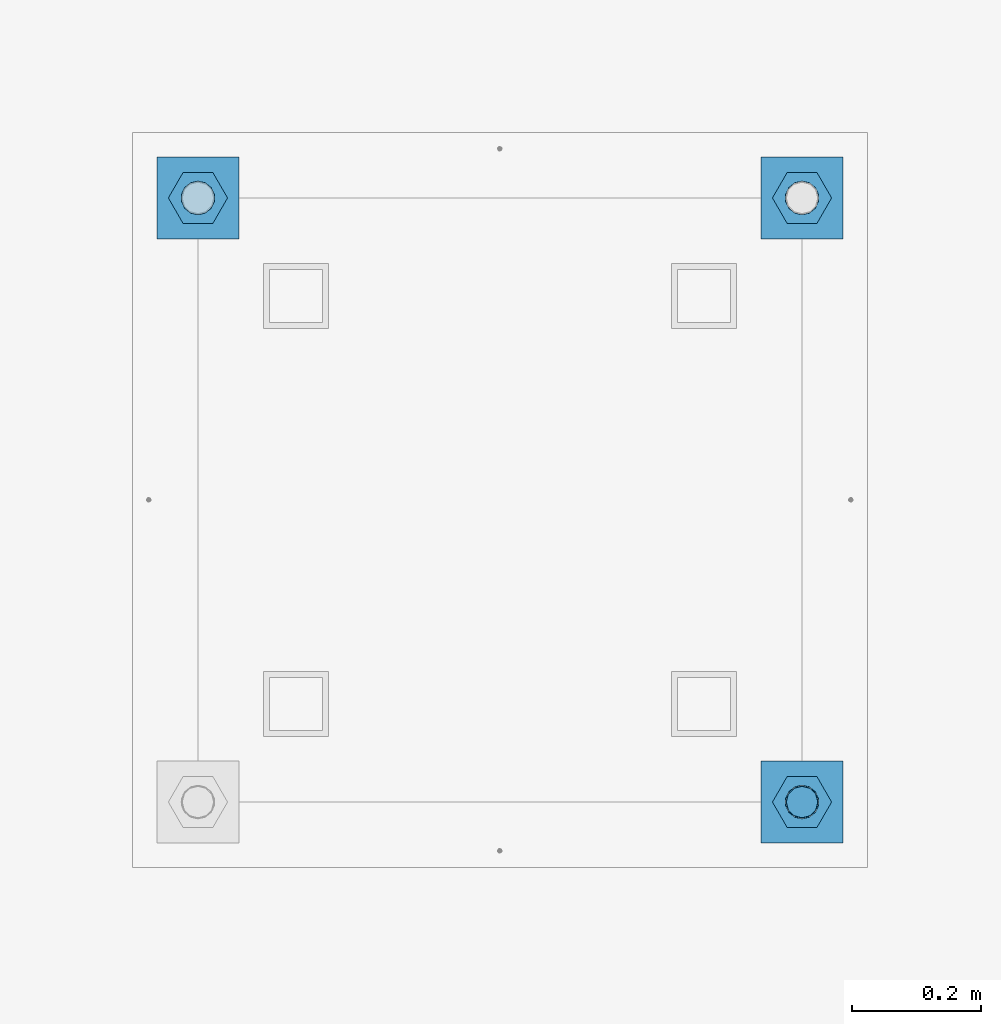
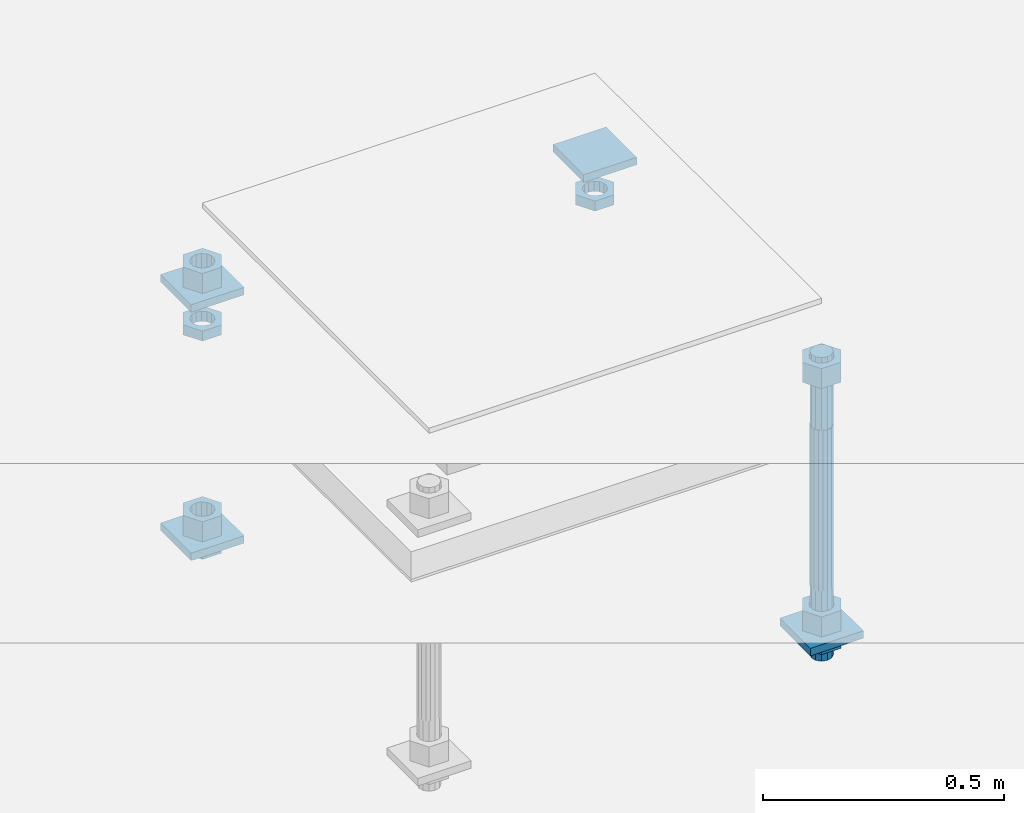
# One storey, part 2597 of 3843: 13 beams, 1 element without a shape of its own.
"""IFC2X3 building model written with IfcOpenShell, lengths in millimetres."""

from ifc_helpers import new_model, si_unit, frame, origin_with_axes, place, context, subcontext, project, spatial, faceted_brep, material, type_object, element, aggregate, save


model = new_model("IFC2X3")

# Units and contexts
model_context = context("Model", 3, precision=1e-05, world=origin_with_axes())
body_context = subcontext(model_context, "Body", "Model", "MODEL_VIEW")
ifc_project = project(units=[si_unit("LENGTHUNIT", "METRE", prefix="MILLI"), si_unit("AREAUNIT", "SQUARE_METRE"), si_unit("VOLUMEUNIT", "CUBIC_METRE"), si_unit("MASSUNIT", "GRAM", prefix="KILO"), si_unit("TIMEUNIT", "SECOND"), si_unit("PLANEANGLEUNIT", "RADIAN"), si_unit("SOLIDANGLEUNIT", "STERADIAN"), si_unit("THERMODYNAMICTEMPERATUREUNIT", "DEGREE_CELSIUS"), si_unit("LUMINOUSINTENSITYUNIT", "LUMEN")], contexts=[model_context])

# Site, building, storey
site_placement = place(None, origin_with_axes())
site = spatial("IfcSite", under=ifc_project, at=site_placement, CompositionType="ELEMENT")
building_placement = place(site_placement, origin_with_axes())
building = spatial("IfcBuilding", under=site, at=building_placement, Name="Undefined", CompositionType="ELEMENT")
storey_placement = place(building_placement, origin_with_axes())
storey = spatial("IfcBuildingStorey", under=building, at=storey_placement, Name="Undefined", CompositionType="ELEMENT", Elevation=0.0)

# Assembly, beams
assembly_placement = place(storey_placement, origin_with_axes())
assembly = element("IfcElementAssembly", 1, at=assembly_placement, inside=storey, Name="TEMPLATE", AssemblyPlace="NOTDEFINED", PredefinedType="RIGID_FRAME")
ifc_material_1 = material(Name="STEEL/A36")
beam_type_1 = type_object("IfcBeamType", PredefinedType="NOTDEFINED")
beam_1_placement = place(assembly_placement, frame((108483.4, 18224.5000015259, 29873.575), z_axis=(1.0, 0.0, 0.0), x_axis=(0.0, 1.0, 0.0)))
beam_1 = element("IfcBeam", 2, at=beam_1_placement, type_object=beam_type_1, material=ifc_material_1, Name="WASHER_PLATE", context=body_context, shape_type="Brep", body=[
    faceted_brep([(0.0, 9.52500000000146, -63.5), (0.0, 9.52500000000146, 63.5), (127.0, 9.52500000000146, 63.5), (127.0, 9.52500000000146, -63.5), (0.0, -9.52500000000146, 63.5), (127.0, -9.52500000000146, 63.5), (0.0, -9.52500000000146, -63.5), (127.0, -9.52500000000146, -63.5)], [[[0, 1, 2, 3]], [[1, 4, 5, 2]], [[4, 6, 7, 5]], [[6, 0, 3, 7]], [[5, 7, 3, 2]], [[6, 4, 1, 0]]]),
])
beam_2_placement = place(assembly_placement, frame((109423.2, 18224.5000015259, 29873.575), z_axis=(1.0, 0.0, 0.0), x_axis=(0.0, 1.0, 0.0)))
beam_2 = element("IfcBeam", 3, at=beam_2_placement, type_object=beam_type_1, material=ifc_material_1, Name="WASHER_PLATE", context=body_context, shape_type="Brep", body=[
    faceted_brep([(0.0, 9.52500000000146, -63.5), (0.0, 9.52500000000146, 63.5), (127.0, 9.52500000000146, 63.5), (127.0, 9.52500000000146, -63.5), (0.0, -9.52500000000146, 63.5), (127.0, -9.52500000000146, 63.5), (0.0, -9.52500000000146, -63.5), (127.0, -9.52500000000146, -63.5)], [[[0, 1, 2, 3]], [[1, 4, 5, 2]], [[4, 6, 7, 5]], [[6, 0, 3, 7]], [[5, 7, 3, 2]], [[6, 4, 1, 0]]]),
])
beam_3_placement = place(assembly_placement, frame((109423.2, 17284.7000015259, 29244.925), z_axis=(1.0, 0.0, 0.0), x_axis=(0.0, 1.0, 0.0)))
beam_3 = element("IfcBeam", 4, at=beam_3_placement, type_object=beam_type_1, material=ifc_material_1, Name="WASHER_PLATE", context=body_context, shape_type="Brep", body=[
    faceted_brep([(0.0, 9.52500000000146, -63.5), (0.0, 9.52500000000146, 63.5), (127.0, 9.52500000000146, 63.5), (127.0, 9.52500000000146, -63.5), (0.0, -9.52500000000146, 63.5), (127.0, -9.52500000000146, 63.5), (0.0, -9.52500000000146, -63.5), (127.0, -9.52500000000146, -63.5)], [[[0, 1, 2, 3]], [[1, 4, 5, 2]], [[4, 6, 7, 5]], [[6, 0, 3, 7]], [[5, 7, 3, 2]], [[6, 4, 1, 0]]]),
])
beam_4_placement = place(assembly_placement, frame((108483.4, 18224.5000015259, 29244.925), z_axis=(1.0, 0.0, 0.0), x_axis=(0.0, 1.0, 0.0)))
beam_4 = element("IfcBeam", 5, at=beam_4_placement, type_object=beam_type_1, material=ifc_material_1, Name="WASHER_PLATE", context=body_context, shape_type="Brep", body=[
    faceted_brep([(0.0, 9.52500000000146, -63.5), (0.0, 9.52500000000146, 63.5), (127.0, 9.52500000000146, 63.5), (127.0, 9.52500000000146, -63.5), (0.0, -9.52500000000146, 63.5), (127.0, -9.52500000000146, 63.5), (0.0, -9.52500000000146, -63.5), (127.0, -9.52500000000146, -63.5)], [[[0, 1, 2, 3]], [[1, 4, 5, 2]], [[4, 6, 7, 5]], [[6, 0, 3, 7]], [[5, 7, 3, 2]], [[6, 4, 1, 0]]]),
])
beam_type_2 = type_object("IfcBeamType", Name="2_HALF_NUT", PredefinedType="NOTDEFINED")
beam_5_placement = place(assembly_placement, frame((108483.4, 18288.0000015259, 29787.85), z_axis=(0.0, -1.0, 0.0), x_axis=(0.0, 0.0, -1.0)))
beam_5 = element("IfcBeam", 6, at=beam_5_placement, type_object=beam_type_2, material=ifc_material_1, Name="NUT", ObjectType="2_HALF_NUT", context=body_context, shape_type="Brep", body=[
    faceted_brep([(0.0, -46.0369987487793, 0.0), (0.0, -23.0184993743896, -39.869213104248), (25.4000000000015, -23.0184993743896, -39.869213104248), (25.4000000000015, -46.0369987487793, 0.0), (0.0, 23.0184993743896, -39.869213104248), (25.4000000000015, 23.0184993743896, -39.869213104248), (0.0, 46.0369987487793, 0.0), (25.4000000000015, 46.0369987487793, 0.0), (0.0, 23.0184993743896, 39.869213104248), (25.4000000000015, 23.0184993743896, 39.869213104248), (0.0, -23.0184993743896, 39.869213104248), (25.4000000000015, -23.0184993743896, 39.869213104248), (0.0, 0.0, 26.1940002441406), (0.0, 11.3650617044477, 23.5999013092805), (25.4000000000015, 11.3650617044477, 23.5999013092805), (25.4000000000015, 0.0, 26.1940002441406), (0.0, 20.4791109456419, 16.3316083006721), (25.4000000000015, 20.4791109456419, 16.3316083006721), (0.0, 25.5370200498292, 5.82867859874386), (25.4000000000015, 25.5370200498292, 5.82867859874386), (0.0, 25.5370200498292, -5.82867859874386), (25.4000000000015, 25.5370200498292, -5.82867859874386), (0.0, 20.4791109456419, -16.3316083006721), (25.4000000000015, 20.4791109456419, -16.3316083006721), (0.0, 11.3650617044477, -23.5999013092805), (25.4000000000015, 11.3650617044477, -23.5999013092805), (0.0, 0.0, -26.1940002441406), (25.4000000000015, 0.0, -26.1940002441406), (0.0, -11.3650617044477, -23.5999013092805), (25.4000000000015, -11.3650617044477, -23.5999013092805), (0.0, -20.4791109456419, -16.3316083006721), (25.4000000000015, -20.4791109456419, -16.3316083006721), (0.0, -25.5370200498292, -5.82867859874386), (25.4000000000015, -25.5370200498292, -5.82867859874386), (0.0, -25.5370200498292, 5.82867859874386), (25.4000000000015, -25.5370200498292, 5.82867859874386), (0.0, -20.4791109456419, 16.3316083006721), (25.4000000000015, -20.4791109456419, 16.3316083006721), (0.0, -11.3650617044477, 23.5999013092805), (25.4000000000015, -11.3650617044477, 23.5999013092805)], [[[0, 1, 2, 3]], [[1, 4, 5, 2]], [[4, 6, 7, 5]], [[6, 8, 9, 7]], [[8, 10, 11, 9]], [[10, 0, 3, 11]], [[12, 13, 14, 15]], [[13, 16, 17, 14]], [[16, 18, 19, 17]], [[18, 20, 21, 19]], [[20, 22, 23, 21]], [[22, 24, 25, 23]], [[24, 26, 27, 25]], [[26, 28, 29, 27]], [[28, 30, 31, 29]], [[30, 32, 33, 31]], [[32, 34, 35, 33]], [[34, 36, 37, 35]], [[36, 38, 39, 37]], [[38, 12, 15, 39]], [[5, 7, 9, 11, 3, 2], [17, 19, 21, 23, 25, 27, 29, 31, 33, 35, 37, 39, 15, 14]], [[10, 8, 6, 4, 1, 0], [38, 36, 34, 32, 30, 28, 26, 24, 22, 20, 18, 16, 13, 12]]]),
])
beam_6_placement = place(assembly_placement, frame((109423.2, 18288.0000015259, 29787.85), z_axis=(0.0, 1.0, 0.0), x_axis=(0.0, 0.0, -1.0)))
beam_6 = element("IfcBeam", 7, at=beam_6_placement, type_object=beam_type_2, material=ifc_material_1, Name="NUT", ObjectType="2_HALF_NUT", context=body_context, shape_type="Brep", body=[
    faceted_brep([(0.0, -46.0369987487793, 0.0), (0.0, -23.0184993743896, -39.869213104248), (25.4000000000015, -23.0184993743896, -39.869213104248), (25.4000000000015, -46.0369987487793, 0.0), (0.0, 23.0184993743896, -39.869213104248), (25.4000000000015, 23.0184993743896, -39.869213104248), (0.0, 46.0369987487793, 0.0), (25.4000000000015, 46.0369987487793, 0.0), (0.0, 23.0184993743896, 39.869213104248), (25.4000000000015, 23.0184993743896, 39.869213104248), (0.0, -23.0184993743896, 39.869213104248), (25.4000000000015, -23.0184993743896, 39.869213104248), (0.0, 0.0, 26.1940002441406), (0.0, 11.3650617044477, 23.5999013092805), (25.4000000000015, 11.3650617044477, 23.5999013092805), (25.4000000000015, 0.0, 26.1940002441406), (0.0, 20.4791109456419, 16.3316083006721), (25.4000000000015, 20.4791109456419, 16.3316083006721), (0.0, 25.5370200498292, 5.82867859874386), (25.4000000000015, 25.5370200498292, 5.82867859874386), (0.0, 25.5370200498292, -5.82867859874386), (25.4000000000015, 25.5370200498292, -5.82867859874386), (0.0, 20.4791109456419, -16.3316083006721), (25.4000000000015, 20.4791109456419, -16.3316083006721), (0.0, 11.3650617044477, -23.5999013092805), (25.4000000000015, 11.3650617044477, -23.5999013092805), (0.0, 0.0, -26.1940002441406), (25.4000000000015, 0.0, -26.1940002441406), (0.0, -11.3650617044477, -23.5999013092805), (25.4000000000015, -11.3650617044477, -23.5999013092805), (0.0, -20.4791109456419, -16.3316083006721), (25.4000000000015, -20.4791109456419, -16.3316083006721), (0.0, -25.5370200498292, -5.82867859874386), (25.4000000000015, -25.5370200498292, -5.82867859874386), (0.0, -25.5370200498292, 5.82867859874386), (25.4000000000015, -25.5370200498292, 5.82867859874386), (0.0, -20.4791109456419, 16.3316083006721), (25.4000000000015, -20.4791109456419, 16.3316083006721), (0.0, -11.3650617044477, 23.5999013092805), (25.4000000000015, -11.3650617044477, 23.5999013092805)], [[[0, 1, 2, 3]], [[1, 4, 5, 2]], [[4, 6, 7, 5]], [[6, 8, 9, 7]], [[8, 10, 11, 9]], [[10, 0, 3, 11]], [[12, 13, 14, 15]], [[13, 16, 17, 14]], [[16, 18, 19, 17]], [[18, 20, 21, 19]], [[20, 22, 23, 21]], [[22, 24, 25, 23]], [[24, 26, 27, 25]], [[26, 28, 29, 27]], [[28, 30, 31, 29]], [[30, 32, 33, 31]], [[32, 34, 35, 33]], [[34, 36, 37, 35]], [[36, 38, 39, 37]], [[38, 12, 15, 39]], [[5, 7, 9, 11, 3, 2], [17, 19, 21, 23, 25, 27, 29, 31, 33, 35, 37, 39, 15, 14]], [[10, 8, 6, 4, 1, 0], [38, 36, 34, 32, 30, 28, 26, 24, 22, 20, 18, 16, 13, 12]]]),
])
beam_7_placement = place(assembly_placement, frame((109423.2, 17348.2000015259, 29235.4), z_axis=(0.0, 1.0, 0.0), x_axis=(0.0, 0.0, -1.0)))
beam_7 = element("IfcBeam", 8, at=beam_7_placement, type_object=beam_type_2, material=ifc_material_1, Name="NUT", ObjectType="2_HALF_NUT", context=body_context, shape_type="Brep", body=[
    faceted_brep([(0.0, -46.0369987487793, 0.0), (0.0, -23.0184993743896, -39.869213104248), (25.4000000000015, -23.0184993743896, -39.869213104248), (25.4000000000015, -46.0369987487793, 0.0), (0.0, 23.0184993743896, -39.869213104248), (25.4000000000015, 23.0184993743896, -39.869213104248), (0.0, 46.0369987487793, 0.0), (25.4000000000015, 46.0369987487793, 0.0), (0.0, 23.0184993743896, 39.869213104248), (25.4000000000015, 23.0184993743896, 39.869213104248), (0.0, -23.0184993743896, 39.869213104248), (25.4000000000015, -23.0184993743896, 39.869213104248), (0.0, 0.0, 26.1940002441406), (0.0, 11.3650617044477, 23.5999013092805), (25.4000000000015, 11.3650617044477, 23.5999013092805), (25.4000000000015, 0.0, 26.1940002441406), (0.0, 20.4791109456419, 16.3316083006721), (25.4000000000015, 20.4791109456419, 16.3316083006721), (0.0, 25.5370200498292, 5.82867859874386), (25.4000000000015, 25.5370200498292, 5.82867859874386), (0.0, 25.5370200498292, -5.82867859874386), (25.4000000000015, 25.5370200498292, -5.82867859874386), (0.0, 20.4791109456419, -16.3316083006721), (25.4000000000015, 20.4791109456419, -16.3316083006721), (0.0, 11.3650617044477, -23.5999013092805), (25.4000000000015, 11.3650617044477, -23.5999013092805), (0.0, 0.0, -26.1940002441406), (25.4000000000015, 0.0, -26.1940002441406), (0.0, -11.3650617044477, -23.5999013092805), (25.4000000000015, -11.3650617044477, -23.5999013092805), (0.0, -20.4791109456419, -16.3316083006721), (25.4000000000015, -20.4791109456419, -16.3316083006721), (0.0, -25.5370200498292, -5.82867859874386), (25.4000000000015, -25.5370200498292, -5.82867859874386), (0.0, -25.5370200498292, 5.82867859874386), (25.4000000000015, -25.5370200498292, 5.82867859874386), (0.0, -20.4791109456419, 16.3316083006721), (25.4000000000015, -20.4791109456419, 16.3316083006721), (0.0, -11.3650617044477, 23.5999013092805), (25.4000000000015, -11.3650617044477, 23.5999013092805)], [[[0, 1, 2, 3]], [[1, 4, 5, 2]], [[4, 6, 7, 5]], [[6, 8, 9, 7]], [[8, 10, 11, 9]], [[10, 0, 3, 11]], [[12, 13, 14, 15]], [[13, 16, 17, 14]], [[16, 18, 19, 17]], [[18, 20, 21, 19]], [[20, 22, 23, 21]], [[22, 24, 25, 23]], [[24, 26, 27, 25]], [[26, 28, 29, 27]], [[28, 30, 31, 29]], [[30, 32, 33, 31]], [[32, 34, 35, 33]], [[34, 36, 37, 35]], [[36, 38, 39, 37]], [[38, 12, 15, 39]], [[5, 7, 9, 11, 3, 2], [17, 19, 21, 23, 25, 27, 29, 31, 33, 35, 37, 39, 15, 14]], [[10, 8, 6, 4, 1, 0], [38, 36, 34, 32, 30, 28, 26, 24, 22, 20, 18, 16, 13, 12]]]),
])
beam_8_placement = place(assembly_placement, frame((108483.4, 18288.0000015259, 29235.4), z_axis=(0.0, -1.0, 0.0), x_axis=(0.0, 0.0, -1.0)))
beam_8 = element("IfcBeam", 9, at=beam_8_placement, type_object=beam_type_2, material=ifc_material_1, Name="NUT", ObjectType="2_HALF_NUT", context=body_context, shape_type="Brep", body=[
    faceted_brep([(0.0, -46.0369987487793, 0.0), (0.0, -23.0184993743896, -39.869213104248), (25.4000000000015, -23.0184993743896, -39.869213104248), (25.4000000000015, -46.0369987487793, 0.0), (0.0, 23.0184993743896, -39.869213104248), (25.4000000000015, 23.0184993743896, -39.869213104248), (0.0, 46.0369987487793, 0.0), (25.4000000000015, 46.0369987487793, 0.0), (0.0, 23.0184993743896, 39.869213104248), (25.4000000000015, 23.0184993743896, 39.869213104248), (0.0, -23.0184993743896, 39.869213104248), (25.4000000000015, -23.0184993743896, 39.869213104248), (0.0, 0.0, 26.1940002441406), (0.0, 11.3650617044477, 23.5999013092805), (25.4000000000015, 11.3650617044477, 23.5999013092805), (25.4000000000015, 0.0, 26.1940002441406), (0.0, 20.4791109456419, 16.3316083006721), (25.4000000000015, 20.4791109456419, 16.3316083006721), (0.0, 25.5370200498292, 5.82867859874386), (25.4000000000015, 25.5370200498292, 5.82867859874386), (0.0, 25.5370200498292, -5.82867859874386), (25.4000000000015, 25.5370200498292, -5.82867859874386), (0.0, 20.4791109456419, -16.3316083006721), (25.4000000000015, 20.4791109456419, -16.3316083006721), (0.0, 11.3650617044477, -23.5999013092805), (25.4000000000015, 11.3650617044477, -23.5999013092805), (0.0, 0.0, -26.1940002441406), (25.4000000000015, 0.0, -26.1940002441406), (0.0, -11.3650617044477, -23.5999013092805), (25.4000000000015, -11.3650617044477, -23.5999013092805), (0.0, -20.4791109456419, -16.3316083006721), (25.4000000000015, -20.4791109456419, -16.3316083006721), (0.0, -25.5370200498292, -5.82867859874386), (25.4000000000015, -25.5370200498292, -5.82867859874386), (0.0, -25.5370200498292, 5.82867859874386), (25.4000000000015, -25.5370200498292, 5.82867859874386), (0.0, -20.4791109456419, 16.3316083006721), (25.4000000000015, -20.4791109456419, 16.3316083006721), (0.0, -11.3650617044477, 23.5999013092805), (25.4000000000015, -11.3650617044477, 23.5999013092805)], [[[0, 1, 2, 3]], [[1, 4, 5, 2]], [[4, 6, 7, 5]], [[6, 8, 9, 7]], [[8, 10, 11, 9]], [[10, 0, 3, 11]], [[12, 13, 14, 15]], [[13, 16, 17, 14]], [[16, 18, 19, 17]], [[18, 20, 21, 19]], [[20, 22, 23, 21]], [[22, 24, 25, 23]], [[24, 26, 27, 25]], [[26, 28, 29, 27]], [[28, 30, 31, 29]], [[30, 32, 33, 31]], [[32, 34, 35, 33]], [[34, 36, 37, 35]], [[36, 38, 39, 37]], [[38, 12, 15, 39]], [[5, 7, 9, 11, 3, 2], [17, 19, 21, 23, 25, 27, 29, 31, 33, 35, 37, 39, 15, 14]], [[10, 8, 6, 4, 1, 0], [38, 36, 34, 32, 30, 28, 26, 24, 22, 20, 18, 16, 13, 12]]]),
])
beam_type_3 = type_object("IfcBeamType", Name="2_HEAVY_HEX_NUT", PredefinedType="NOTDEFINED")
beam_9_placement = place(assembly_placement, frame((109423.2, 17348.2000015259, 29933.9), z_axis=(0.0, 1.0, 0.0), x_axis=(0.0, 0.0, -1.0)))
beam_9 = element("IfcBeam", 10, at=beam_9_placement, type_object=beam_type_3, material=ifc_material_1, Name="NUT", ObjectType="2_HEAVY_HEX_NUT", context=body_context, shape_type="Brep", body=[
    faceted_brep([(0.0, -46.0369987487793, 0.0), (0.0, -23.0184993743896, -39.869213104248), (50.7999999999993, -23.0184993743896, -39.869213104248), (50.7999999999993, -46.0369987487793, 0.0), (0.0, 23.0184993743896, -39.869213104248), (50.7999999999993, 23.0184993743896, -39.869213104248), (0.0, 46.0369987487793, 0.0), (50.7999999999993, 46.0369987487793, 0.0), (0.0, 23.0184993743896, 39.869213104248), (50.7999999999993, 23.0184993743896, 39.869213104248), (0.0, -23.0184993743896, 39.869213104248), (50.7999999999993, -23.0184993743896, 39.869213104248), (0.0, 0.0, 26.1940002441406), (0.0, 11.3650617044477, 23.5999013092805), (50.7999999999993, 11.3650617044477, 23.5999013092805), (50.7999999999993, 0.0, 26.1940002441406), (0.0, 20.4791109456419, 16.3316083006721), (50.7999999999993, 20.4791109456419, 16.3316083006721), (0.0, 25.5370200498292, 5.82867859874386), (50.7999999999993, 25.5370200498292, 5.82867859874386), (0.0, 25.5370200498292, -5.82867859874386), (50.7999999999993, 25.5370200498292, -5.82867859874386), (0.0, 20.4791109456419, -16.3316083006721), (50.7999999999993, 20.4791109456419, -16.3316083006721), (0.0, 11.3650617044477, -23.5999013092805), (50.7999999999993, 11.3650617044477, -23.5999013092805), (0.0, 0.0, -26.1940002441406), (50.7999999999993, 0.0, -26.1940002441406), (0.0, -11.3650617044477, -23.5999013092805), (50.7999999999993, -11.3650617044477, -23.5999013092805), (0.0, -20.4791109456419, -16.3316083006721), (50.7999999999993, -20.4791109456419, -16.3316083006721), (0.0, -25.5370200498292, -5.82867859874386), (50.7999999999993, -25.5370200498292, -5.82867859874386), (0.0, -25.5370200498292, 5.82867859874386), (50.7999999999993, -25.5370200498292, 5.82867859874386), (0.0, -20.4791109456419, 16.3316083006721), (50.7999999999993, -20.4791109456419, 16.3316083006721), (0.0, -11.3650617044477, 23.5999013092805), (50.7999999999993, -11.3650617044477, 23.5999013092805)], [[[0, 1, 2, 3]], [[1, 4, 5, 2]], [[4, 6, 7, 5]], [[6, 8, 9, 7]], [[8, 10, 11, 9]], [[10, 0, 3, 11]], [[12, 13, 14, 15]], [[13, 16, 17, 14]], [[16, 18, 19, 17]], [[18, 20, 21, 19]], [[20, 22, 23, 21]], [[22, 24, 25, 23]], [[24, 26, 27, 25]], [[26, 28, 29, 27]], [[28, 30, 31, 29]], [[30, 32, 33, 31]], [[32, 34, 35, 33]], [[34, 36, 37, 35]], [[36, 38, 39, 37]], [[38, 12, 15, 39]], [[5, 7, 9, 11, 3, 2], [17, 19, 21, 23, 25, 27, 29, 31, 33, 35, 37, 39, 15, 14]], [[10, 8, 6, 4, 1, 0], [38, 36, 34, 32, 30, 28, 26, 24, 22, 20, 18, 16, 13, 12]]]),
])
beam_10_placement = place(assembly_placement, frame((109423.2, 17348.2000015259, 29305.25), z_axis=(0.0, 1.0, 0.0), x_axis=(0.0, 0.0, -1.0)))
beam_10 = element("IfcBeam", 11, at=beam_10_placement, type_object=beam_type_3, material=ifc_material_1, Name="NUT", ObjectType="2_HEAVY_HEX_NUT", context=body_context, shape_type="Brep", body=[
    faceted_brep([(0.0, -46.0369987487793, 0.0), (0.0, -23.0184993743896, -39.869213104248), (50.7999999999993, -23.0184993743896, -39.869213104248), (50.7999999999993, -46.0369987487793, 0.0), (0.0, 23.0184993743896, -39.869213104248), (50.7999999999993, 23.0184993743896, -39.869213104248), (0.0, 46.0369987487793, 0.0), (50.7999999999993, 46.0369987487793, 0.0), (0.0, 23.0184993743896, 39.869213104248), (50.7999999999993, 23.0184993743896, 39.869213104248), (0.0, -23.0184993743896, 39.869213104248), (50.7999999999993, -23.0184993743896, 39.869213104248), (0.0, 0.0, 26.1940002441406), (0.0, 11.3650617044477, 23.5999013092805), (50.7999999999993, 11.3650617044477, 23.5999013092805), (50.7999999999993, 0.0, 26.1940002441406), (0.0, 20.4791109456419, 16.3316083006721), (50.7999999999993, 20.4791109456419, 16.3316083006721), (0.0, 25.5370200498292, 5.82867859874386), (50.7999999999993, 25.5370200498292, 5.82867859874386), (0.0, 25.5370200498292, -5.82867859874386), (50.7999999999993, 25.5370200498292, -5.82867859874386), (0.0, 20.4791109456419, -16.3316083006721), (50.7999999999993, 20.4791109456419, -16.3316083006721), (0.0, 11.3650617044477, -23.5999013092805), (50.7999999999993, 11.3650617044477, -23.5999013092805), (0.0, 0.0, -26.1940002441406), (50.7999999999993, 0.0, -26.1940002441406), (0.0, -11.3650617044477, -23.5999013092805), (50.7999999999993, -11.3650617044477, -23.5999013092805), (0.0, -20.4791109456419, -16.3316083006721), (50.7999999999993, -20.4791109456419, -16.3316083006721), (0.0, -25.5370200498292, -5.82867859874386), (50.7999999999993, -25.5370200498292, -5.82867859874386), (0.0, -25.5370200498292, 5.82867859874386), (50.7999999999993, -25.5370200498292, 5.82867859874386), (0.0, -20.4791109456419, 16.3316083006721), (50.7999999999993, -20.4791109456419, 16.3316083006721), (0.0, -11.3650617044477, 23.5999013092805), (50.7999999999993, -11.3650617044477, 23.5999013092805)], [[[0, 1, 2, 3]], [[1, 4, 5, 2]], [[4, 6, 7, 5]], [[6, 8, 9, 7]], [[8, 10, 11, 9]], [[10, 0, 3, 11]], [[12, 13, 14, 15]], [[13, 16, 17, 14]], [[16, 18, 19, 17]], [[18, 20, 21, 19]], [[20, 22, 23, 21]], [[22, 24, 25, 23]], [[24, 26, 27, 25]], [[26, 28, 29, 27]], [[28, 30, 31, 29]], [[30, 32, 33, 31]], [[32, 34, 35, 33]], [[34, 36, 37, 35]], [[36, 38, 39, 37]], [[38, 12, 15, 39]], [[5, 7, 9, 11, 3, 2], [17, 19, 21, 23, 25, 27, 29, 31, 33, 35, 37, 39, 15, 14]], [[10, 8, 6, 4, 1, 0], [38, 36, 34, 32, 30, 28, 26, 24, 22, 20, 18, 16, 13, 12]]]),
])
beam_11_placement = place(assembly_placement, frame((108483.4, 18288.0000015259, 29933.9), z_axis=(0.0, -1.0, 0.0), x_axis=(0.0, 0.0, -1.0)))
beam_11 = element("IfcBeam", 12, at=beam_11_placement, type_object=beam_type_3, material=ifc_material_1, Name="NUT", ObjectType="2_HEAVY_HEX_NUT", context=body_context, shape_type="Brep", body=[
    faceted_brep([(0.0, -46.0369987487793, 0.0), (0.0, -23.0184993743896, -39.869213104248), (50.7999999999993, -23.0184993743896, -39.869213104248), (50.7999999999993, -46.0369987487793, 0.0), (0.0, 23.0184993743896, -39.869213104248), (50.7999999999993, 23.0184993743896, -39.869213104248), (0.0, 46.0369987487793, 0.0), (50.7999999999993, 46.0369987487793, 0.0), (0.0, 23.0184993743896, 39.869213104248), (50.7999999999993, 23.0184993743896, 39.869213104248), (0.0, -23.0184993743896, 39.869213104248), (50.7999999999993, -23.0184993743896, 39.869213104248), (0.0, 0.0, 26.1940002441406), (0.0, 11.3650617044477, 23.5999013092805), (50.7999999999993, 11.3650617044477, 23.5999013092805), (50.7999999999993, 0.0, 26.1940002441406), (0.0, 20.4791109456419, 16.3316083006721), (50.7999999999993, 20.4791109456419, 16.3316083006721), (0.0, 25.5370200498292, 5.82867859874386), (50.7999999999993, 25.5370200498292, 5.82867859874386), (0.0, 25.5370200498292, -5.82867859874386), (50.7999999999993, 25.5370200498292, -5.82867859874386), (0.0, 20.4791109456419, -16.3316083006721), (50.7999999999993, 20.4791109456419, -16.3316083006721), (0.0, 11.3650617044477, -23.5999013092805), (50.7999999999993, 11.3650617044477, -23.5999013092805), (0.0, 0.0, -26.1940002441406), (50.7999999999993, 0.0, -26.1940002441406), (0.0, -11.3650617044477, -23.5999013092805), (50.7999999999993, -11.3650617044477, -23.5999013092805), (0.0, -20.4791109456419, -16.3316083006721), (50.7999999999993, -20.4791109456419, -16.3316083006721), (0.0, -25.5370200498292, -5.82867859874386), (50.7999999999993, -25.5370200498292, -5.82867859874386), (0.0, -25.5370200498292, 5.82867859874386), (50.7999999999993, -25.5370200498292, 5.82867859874386), (0.0, -20.4791109456419, 16.3316083006721), (50.7999999999993, -20.4791109456419, 16.3316083006721), (0.0, -11.3650617044477, 23.5999013092805), (50.7999999999993, -11.3650617044477, 23.5999013092805)], [[[0, 1, 2, 3]], [[1, 4, 5, 2]], [[4, 6, 7, 5]], [[6, 8, 9, 7]], [[8, 10, 11, 9]], [[10, 0, 3, 11]], [[12, 13, 14, 15]], [[13, 16, 17, 14]], [[16, 18, 19, 17]], [[18, 20, 21, 19]], [[20, 22, 23, 21]], [[22, 24, 25, 23]], [[24, 26, 27, 25]], [[26, 28, 29, 27]], [[28, 30, 31, 29]], [[30, 32, 33, 31]], [[32, 34, 35, 33]], [[34, 36, 37, 35]], [[36, 38, 39, 37]], [[38, 12, 15, 39]], [[5, 7, 9, 11, 3, 2], [17, 19, 21, 23, 25, 27, 29, 31, 33, 35, 37, 39, 15, 14]], [[10, 8, 6, 4, 1, 0], [38, 36, 34, 32, 30, 28, 26, 24, 22, 20, 18, 16, 13, 12]]]),
])
beam_12_placement = place(assembly_placement, frame((108483.4, 18288.0000015259, 29305.25), z_axis=(0.0, -1.0, 0.0), x_axis=(0.0, 0.0, -1.0)))
beam_12 = element("IfcBeam", 13, at=beam_12_placement, type_object=beam_type_3, material=ifc_material_1, Name="NUT", ObjectType="2_HEAVY_HEX_NUT", context=body_context, shape_type="Brep", body=[
    faceted_brep([(0.0, -46.0369987487793, 0.0), (0.0, -23.0184993743896, -39.869213104248), (50.7999999999993, -23.0184993743896, -39.869213104248), (50.7999999999993, -46.0369987487793, 0.0), (0.0, 23.0184993743896, -39.869213104248), (50.7999999999993, 23.0184993743896, -39.869213104248), (0.0, 46.0369987487793, 0.0), (50.7999999999993, 46.0369987487793, 0.0), (0.0, 23.0184993743896, 39.869213104248), (50.7999999999993, 23.0184993743896, 39.869213104248), (0.0, -23.0184993743896, 39.869213104248), (50.7999999999993, -23.0184993743896, 39.869213104248), (0.0, 0.0, 26.1940002441406), (0.0, 11.3650617044477, 23.5999013092805), (50.7999999999993, 11.3650617044477, 23.5999013092805), (50.7999999999993, 0.0, 26.1940002441406), (0.0, 20.4791109456419, 16.3316083006721), (50.7999999999993, 20.4791109456419, 16.3316083006721), (0.0, 25.5370200498292, 5.82867859874386), (50.7999999999993, 25.5370200498292, 5.82867859874386), (0.0, 25.5370200498292, -5.82867859874386), (50.7999999999993, 25.5370200498292, -5.82867859874386), (0.0, 20.4791109456419, -16.3316083006721), (50.7999999999993, 20.4791109456419, -16.3316083006721), (0.0, 11.3650617044477, -23.5999013092805), (50.7999999999993, 11.3650617044477, -23.5999013092805), (0.0, 0.0, -26.1940002441406), (50.7999999999993, 0.0, -26.1940002441406), (0.0, -11.3650617044477, -23.5999013092805), (50.7999999999993, -11.3650617044477, -23.5999013092805), (0.0, -20.4791109456419, -16.3316083006721), (50.7999999999993, -20.4791109456419, -16.3316083006721), (0.0, -25.5370200498292, -5.82867859874386), (50.7999999999993, -25.5370200498292, -5.82867859874386), (0.0, -25.5370200498292, 5.82867859874386), (50.7999999999993, -25.5370200498292, 5.82867859874386), (0.0, -20.4791109456419, 16.3316083006721), (50.7999999999993, -20.4791109456419, 16.3316083006721), (0.0, -11.3650617044477, 23.5999013092805), (50.7999999999993, -11.3650617044477, 23.5999013092805)], [[[0, 1, 2, 3]], [[1, 4, 5, 2]], [[4, 6, 7, 5]], [[6, 8, 9, 7]], [[8, 10, 11, 9]], [[10, 0, 3, 11]], [[12, 13, 14, 15]], [[13, 16, 17, 14]], [[16, 18, 19, 17]], [[18, 20, 21, 19]], [[20, 22, 23, 21]], [[22, 24, 25, 23]], [[24, 26, 27, 25]], [[26, 28, 29, 27]], [[28, 30, 31, 29]], [[30, 32, 33, 31]], [[32, 34, 35, 33]], [[34, 36, 37, 35]], [[36, 38, 39, 37]], [[38, 12, 15, 39]], [[5, 7, 9, 11, 3, 2], [17, 19, 21, 23, 25, 27, 29, 31, 33, 35, 37, 39, 15, 14]], [[10, 8, 6, 4, 1, 0], [38, 36, 34, 32, 30, 28, 26, 24, 22, 20, 18, 16, 13, 12]]]),
])
ifc_material_2 = material()
beam_type_4 = type_object("IfcBeamType", PredefinedType="NOTDEFINED")
beam_13_placement = place(assembly_placement, frame((109423.2, 17348.2000015259, 29762.45), z_axis=(0.0, 1.0, 0.0), x_axis=(0.0, 0.0, -1.0)))
beam_13 = element("IfcBeam", 14, at=beam_13_placement, type_object=beam_type_4, material=ifc_material_2, Name="ANCHOR_ROD", context=body_context, shape_type="Brep", body=[
    faceted_brep([(-184.150000000001, -21.217622392709, 12.25), (-184.150000000001, -12.2499999999854, 21.2176223927163), (-184.150000000001, 1.45519152283669e-11, 24.5), (-184.150000000001, 12.2500000000146, 21.2176223927163), (-184.150000000001, 21.2176223927381, 12.25), (-184.150000000001, 24.5000000000146, 0.0), (-184.150000000001, 21.2176223927381, -12.25), (-184.150000000001, 12.2500000000146, -21.2176223927163), (-184.150000000001, 1.45519152283669e-11, -24.5), (-184.150000000001, -12.2499999999854, -21.2176223927163), (-184.150000000001, -21.217622392709, -12.25), (-184.150000000001, -24.4999999999854, 0.0), (0.0, 24.5000000000146, 0.0), (0.0, 21.2176223927381, -12.25), (0.0, 12.2500000000146, -21.2176223927163), (0.0, 1.45519152283669e-11, -24.5), (0.0, -12.2499999999854, -21.2176223927163), (0.0, -21.217622392709, -12.25), (0.0, -24.4999999999854, 0.0), (0.0, -21.217622392709, 12.25), (0.0, -12.2499999999854, 21.2176223927163), (0.0, 1.45519152283669e-11, 24.5), (0.0, 12.2500000000146, 21.2176223927163), (0.0, 21.2176223927381, 12.25), (0.0, -23.4665401257807, 9.72015918207035), (0.0, -17.9605122421344, 17.9605122421417), (0.0, -9.72015918207762, 23.466540125788), (0.0, 0.0, 25.4000000000015), (0.0, 9.72015918207762, 23.466540125788), (0.0, 17.9605122421344, 17.9605122421417), (0.0, 23.4665401257807, 9.72015918207035), (0.0, 25.3999996185303, 0.0), (0.0, 23.4665401257807, -9.72015918207035), (0.0, 17.9605122421344, -17.9605122421417), (0.0, 9.72015918207762, -23.466540125788), (0.0, 0.0, -25.4000000000015), (0.0, -9.72015918207762, -23.466540125788), (0.0, -17.9605122421344, -17.9605122421417), (0.0, -23.4665401257807, -9.72015918207035), (0.0, -25.3999996185303, 0.0), (406.399999999998, -25.3999999999942, 0.0), (406.399999999998, -23.4665401257807, 9.72015918207035), (406.399999999998, -17.9605122421344, 17.9605122421417), (406.399999999998, -9.72015918207762, 23.466540125788), (406.399999999998, 0.0, 25.4000000000015), (406.399999999998, 9.72015918207762, 23.466540125788), (406.399999999998, 17.9605122421344, 17.9605122421417), (406.399999999998, 23.4665401257807, 9.72015918207035), (406.399999999998, 25.3999999999942, 0.0), (406.399999999998, 23.4665401257807, -9.72015918207035), (406.399999999998, 17.9605122421344, -17.9605122421417), (406.399999999998, 9.72015918207762, -23.466540125788), (406.399999999998, 0.0, -25.4000000000015), (406.399999999998, -9.72015918207762, -23.466540125788), (406.399999999998, -17.9605122421344, -17.9605122421417), (406.399999999998, -23.4665401257807, -9.72015918207035), (406.399999999998, -12.2499999999854, 21.2176223927163), (406.399999999998, 1.45519152283669e-11, 24.5), (406.399999999998, 12.2500000000146, 21.2176223927163), (406.399999999998, 21.2176223927381, 12.25), (406.399999999998, 24.5000000000146, 0.0), (406.399999999998, 21.2176223927381, -12.25), (406.399999999998, 12.2500000000146, -21.2176223927163), (406.399999999998, 1.45519152283669e-11, -24.5), (406.399999999998, -12.2499999999854, -21.2176223927163), (406.399999999998, -21.217622392709, -12.25), (406.399999999998, -24.4999999999854, 0.0), (406.399999999998, -21.217622392709, 12.25), (584.200000000001, -12.2499999999854, -21.2176223927163), (584.200000000001, 1.45519152283669e-11, -24.5), (584.200000000001, 12.2500000000146, -21.2176223927163), (584.200000000001, 21.2176223927381, -12.25), (584.200000000001, 24.5000000000146, 0.0), (584.200000000001, 21.2176223927381, 12.25), (584.200000000001, 12.2500000000146, 21.2176223927163), (584.200000000001, 1.45519152283669e-11, 24.5), (584.200000000001, -12.2499999999854, 21.2176223927163), (584.200000000001, -21.217622392709, 12.25), (584.200000000001, -24.4999999999854, 0.0), (584.200000000001, -21.217622392709, -12.25)], [[[0, 1, 2, 3, 4, 5, 6, 7, 8, 9, 10, 11]], [[6, 5, 12, 13]], [[7, 6, 13, 14]], [[8, 7, 14, 15]], [[9, 8, 15, 16]], [[10, 9, 16, 17]], [[11, 10, 17, 18]], [[0, 11, 18, 19]], [[1, 0, 19, 20]], [[2, 1, 20, 21]], [[3, 2, 21, 22]], [[4, 3, 22, 23]], [[5, 4, 23, 12]], [[24, 25, 26, 27, 28, 29, 30, 31, 32, 33, 34, 35, 36, 37, 38, 39], [22, 21, 20, 19, 18, 17, 16, 15, 14, 13, 12, 23]], [[24, 39, 40, 41]], [[25, 24, 41, 42]], [[26, 25, 42, 43]], [[27, 26, 43, 44]], [[28, 27, 44, 45]], [[29, 28, 45, 46]], [[30, 29, 46, 47]], [[31, 30, 47, 48]], [[32, 31, 48, 49]], [[33, 32, 49, 50]], [[34, 33, 50, 51]], [[35, 34, 51, 52]], [[36, 35, 52, 53]], [[37, 36, 53, 54]], [[38, 37, 54, 55]], [[39, 38, 55, 40]], [[54, 53, 52, 51, 50, 49, 48, 47, 46, 45, 44, 43, 42, 41, 40, 55], [56, 57, 58, 59, 60, 61, 62, 63, 64, 65, 66, 67]], [[68, 69, 70, 71, 72, 73, 74, 75, 76, 77, 78, 79]], [[76, 75, 57, 56]], [[77, 76, 56, 67]], [[78, 77, 67, 66]], [[79, 78, 66, 65]], [[68, 79, 65, 64]], [[69, 68, 64, 63]], [[70, 69, 63, 62]], [[71, 70, 62, 61]], [[72, 71, 61, 60]], [[73, 72, 60, 59]], [[74, 73, 59, 58]], [[75, 74, 58, 57]]]),
])
aggregate(assembly, [beam_5, beam_6, beam_1, beam_2, beam_9, beam_10, beam_7, beam_3, beam_13, beam_11, beam_12, beam_8, beam_4])

save(model, "model.ifc")
